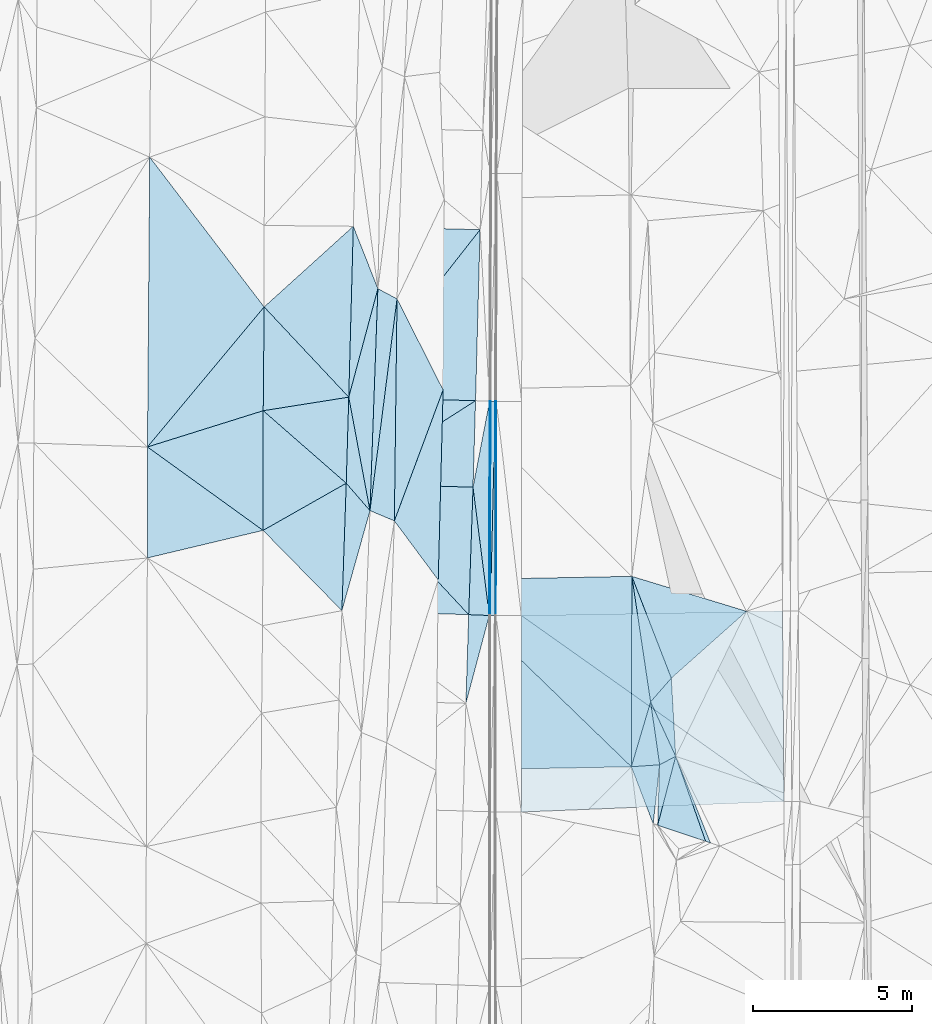
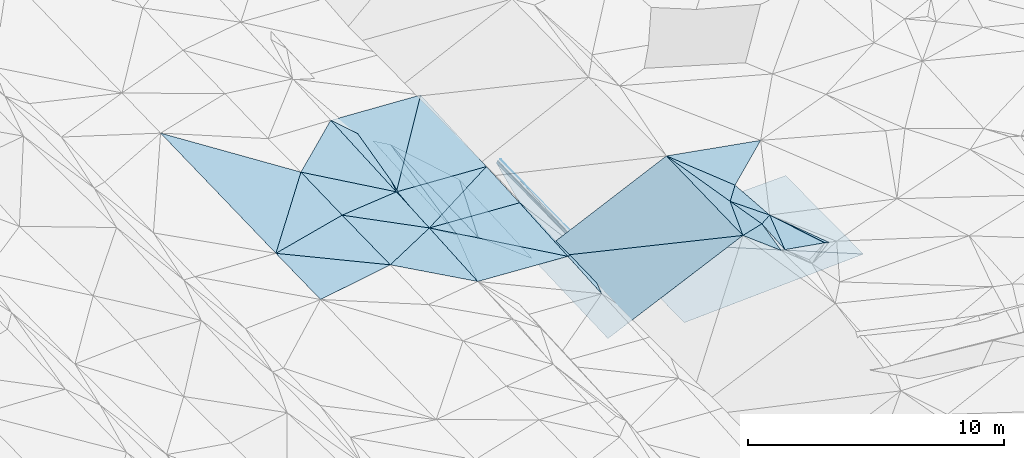
# One storey, part 113 of 275: 45 plates.
"""IFC2X3 building model written with IfcOpenShell, lengths in millimetres."""

from ifc_helpers import new_model, si_unit, frame, origin_with_axes, place, context, subcontext, project, spatial, polyline, outline, extrude, material, type_object, element, save


model = new_model("IFC2X3")

# Units and contexts
model_context = context("Model", 3, precision=1e-05, world=origin_with_axes())
body_context = subcontext(model_context, "Body", "Model", "MODEL_VIEW")
ifc_project = project(units=[si_unit("LENGTHUNIT", "METRE", prefix="MILLI"), si_unit("AREAUNIT", "SQUARE_METRE"), si_unit("VOLUMEUNIT", "CUBIC_METRE"), si_unit("MASSUNIT", "GRAM", prefix="KILO"), si_unit("TIMEUNIT", "SECOND"), si_unit("PLANEANGLEUNIT", "RADIAN"), si_unit("SOLIDANGLEUNIT", "STERADIAN"), si_unit("THERMODYNAMICTEMPERATUREUNIT", "DEGREE_CELSIUS"), si_unit("LUMINOUSINTENSITYUNIT", "LUMEN")], contexts=[model_context])

# Site, building, storey
site_placement = place(None, origin_with_axes())
site = spatial("IfcSite", under=ifc_project, at=site_placement, CompositionType="ELEMENT")
building_placement = place(site_placement, origin_with_axes())
building = spatial("IfcBuilding", under=site, at=building_placement, Name="Undefined", CompositionType="ELEMENT")
storey_placement = place(building_placement, origin_with_axes())
storey = spatial("IfcBuildingStorey", under=building, at=storey_placement, Name="Undefined", CompositionType="ELEMENT", Elevation=0.0)

# Plates
ifc_material = material()
plate_type_1 = type_object("IfcPlateType", PredefinedType="NOTDEFINED")
plate_1_placement = place(storey_placement, frame((-57909.1824641043, 101493.353414711, 43028.0133275653), z_axis=(-0.031047269517772, 0.0185292293777229, -0.999346153599522), x_axis=(-0.61710853961747, -0.786864696567594, 0.00458253497328638)))
element("IfcPlate", 1, at=plate_1_placement, inside=storey, type_object=plate_type_1, material=ifc_material, Name="00_PR", context=body_context, shape_type="SweptSolid", body=[
    extrude(outline(polyline([(0.0, 0.0), (6712.22412109375, -2.40543158724904e-08), (2384.2900390625, 3214.20239257813), (0.0, 0.0)])), frame((-8.85201319254618e-08, 2.18876761149539e-07, -0.5000001331573), z_axis=(0.0, 0.0, 1.0), x_axis=(1.0, 0.0, 0.0)), (0.0, 0.0, 1.0), 1.0),
])
plate_type_2 = type_object("IfcPlateType", PredefinedType="NOTDEFINED")
plate_2_placement = place(storey_placement, frame((-62051.3529860005, 96211.7411999323, 43058.7723184835), z_axis=(-0.0306633647519783, 0.0182280459440001, -0.999363545664515), x_axis=(0.617108539617754, 0.786864696567359, -0.00458253497537088)))
element("IfcPlate", 2, at=plate_2_placement, inside=storey, type_object=plate_type_2, material=ifc_material, Name="00_PR", context=body_context, shape_type="SweptSolid", body=[
    extrude(outline(polyline([(0.0, 0.0), (6712.22412109375, -2.40543158724904e-08), (2380.068359375, 3217.27490234375), (0.0, 0.0)])), frame((-8.85201319254618e-08, 2.18876761149539e-07, -0.5000001331573), z_axis=(0.0, 0.0, 1.0), x_axis=(1.0, 0.0, 0.0)), (0.0, 0.0, 1.0), 1.0),
])
plate_type_3 = type_object("IfcPlateType", PredefinedType="NOTDEFINED")
plate_3_placement = place(storey_placement, frame((-58052.9123680418, 96099.9369413555, 42934.0493217703), z_axis=(-0.0306527454789538, 0.0186005279170604, -0.999357008058586), x_axis=(-0.842895420064381, -0.537844130072321, 0.01584306098071)))
element("IfcPlate", 3, at=plate_3_placement, inside=storey, type_object=plate_type_3, material=ifc_material, Name="00_PR", context=body_context, shape_type="SweptSolid", body=[
    extrude(outline(polyline([(0.0, 0.0), (4837.9541015625, 1.08848325908184e-08), (3312.10986328125, 2246.2216796875), (0.0, 0.0)])), frame((-8.85201319254618e-08, 2.18876761149539e-07, -0.5000001331573), z_axis=(0.0, 0.0, 1.0), x_axis=(1.0, 0.0, 0.0)), (0.0, 0.0, 1.0), 1.0),
])
plate_type_4 = type_object("IfcPlateType", PredefinedType="NOTDEFINED")
plate_4_placement = place(storey_placement, frame((-62130.801419067, 93497.8718170741, 43010.6973171979), z_axis=(-0.0303957004694243, 0.0185568399053159, -0.999365671356437), x_axis=(0.999019561464119, -0.0316325339894895, -0.0309725459954905)))
element("IfcPlate", 4, at=plate_4_placement, inside=storey, type_object=plate_type_4, material=ifc_material, Name="00_PR", context=body_context, shape_type="SweptSolid", body=[
    extrude(outline(polyline([(0.0, 0.0), (4001.93115234375, 7.15954229235649e-09), (3994.52514648438, 4020.86645507813), (0.0, 0.0)])), frame((-8.85201319254618e-08, 2.18876761149539e-07, -0.5000001331573), z_axis=(0.0, 0.0, 1.0), x_axis=(1.0, 0.0, 0.0)), (0.0, 0.0, 1.0), 1.0),
])
plate_5_placement = place(storey_placement, frame((-58269.6130012271, 89353.3534761525, 42816.3013160136), z_axis=(-0.0302048589805003, 0.0187347511255781, -0.999368138172431), x_axis=(-0.999029709474089, 0.0314947659948282, 0.0307850499926167)))
element("IfcPlate", 5, at=plate_5_placement, inside=storey, type_object=plate_type_4, material=ifc_material, Name="00_PR", context=body_context, shape_type="SweptSolid", body=[
    extrude(outline(polyline([(0.0, 0.0), (4001.91015625, 1.07684172689915e-09), (3993.95703125, 4021.43090820313), (0.0, 0.0)])), frame((-8.85201319254618e-08, 2.18876761149539e-07, -0.5000001331573), z_axis=(0.0, 0.0, 1.0), x_axis=(1.0, 0.0, 0.0)), (0.0, 0.0, 1.0), 1.0),
])
plate_type_5 = type_object("IfcPlateType", PredefinedType="NOTDEFINED")
plate_6_placement = place(storey_placement, frame((-57579.2497598258, 96081.7945022669, 43068.247733589), z_axis=(0.970139764418212, 0.00259640183563842, -0.24253267036027), x_axis=(-0.0014779509858692, -0.999860841220768, -0.0166166739807462)))
element("IfcPlate", 6, at=plate_6_placement, inside=storey, type_object=plate_type_5, material=ifc_material, Name="00_PR", context=body_context, shape_type="SweptSolid", body=[
    extrude(outline(polyline([(0.0, 0.0), (6754.7666015625, -3.88390617445111e-08), (6756.96630859375, 123.673530578613), (0.0, 0.0)])), frame((-8.85201319254618e-08, 2.18876761149539e-07, -0.5000001331573), z_axis=(0.0, 0.0, 1.0), x_axis=(1.0, 0.0, 0.0)), (0.0, 0.0, 1.0), 1.0),
])
plate_7_placement = place(storey_placement, frame((-57609.2393043283, 96086.9550963816, 42948.3347430458), z_axis=(0.970144011297878, 0.00259579263473839, -0.242515688571814), x_axis=(0.242410465096964, -0.0417139529857139, 0.969276592381029)))
element("IfcPlate", 7, at=plate_7_placement, inside=storey, type_object=plate_type_5, material=ifc_material, Name="00_PR", context=body_context, shape_type="SweptSolid", body=[
    extrude(outline(polyline([(0.0, 0.0), (123.713912963867, -8.73114913702011e-11), (170.653244018555, 6757.93505859375), (0.0, 0.0)])), frame((-8.85201319254618e-08, 2.18876761149539e-07, -0.5000001331573), z_axis=(0.0, 0.0, 1.0), x_axis=(1.0, 0.0, 0.0)), (0.0, 0.0, 1.0), 1.0),
])
plate_8_placement = place(storey_placement, frame((-51741.9958001236, 84887.2213119148, 45209.5000361991), z_axis=(0.00429473827097584, 0.0127171600984448, -0.999909910473046), x_axis=(0.372999397494959, -0.927775542532137, -0.0101976540241572)))
element("IfcPlate", 8, at=plate_8_placement, inside=storey, type_object=plate_type_5, material=ifc_material, Name="00", context=body_context, shape_type="SweptSolid", body=[
    extrude(outline(polyline([(0.0, 0.0), (2941.85327148438, -1.34077708935365e-08), (2836.00146484375, 123.674690246582), (0.0, 0.0)])), frame((-8.85201319254618e-08, 2.18876761149539e-07, -0.5000001331573), z_axis=(0.0, 0.0, 1.0), x_axis=(1.0, 0.0, 0.0)), (0.0, 0.0, 1.0), 1.0),
])
plate_type_6 = type_object("IfcPlateType", PredefinedType="NOTDEFINED")
plate_9_placement = place(storey_placement, frame((-57429.7352773586, 96081.3448636634, 43067.8690700577), z_axis=(5.05853853107608e-05, 0.0166162104623777, -0.999861939965208), x_axis=(-0.023679539994223, -0.999581560432695, -0.016612748977818)))
element("IfcPlate", 9, at=plate_9_placement, inside=storey, type_object=plate_type_6, material=ifc_material, Name="00_PR", context=body_context, shape_type="SweptSolid", body=[
    extrude(outline(polyline([(0.0, 0.0), (6756.19677734375, 4.00905264541507e-08), (3.09546446800232, 149.968276977539), (0.0, 0.0)])), frame((-8.85201319254618e-08, 2.18876761149539e-07, -0.5000001331573), z_axis=(0.0, 0.0, 1.0), x_axis=(1.0, 0.0, 0.0)), (0.0, 0.0, 1.0), 1.0),
])
plate_10_placement = place(storey_placement, frame((-57589.7189224863, 89327.9750775003, 42955.6300715467), z_axis=(3.61554602707048e-05, 0.0166165522165428, -0.999861934911625), x_axis=(0.023679539977484, 0.999581560433073, 0.0166127489789523)))
element("IfcPlate", 10, at=plate_10_placement, inside=storey, type_object=plate_type_6, material=ifc_material, Name="00_PR", context=body_context, shape_type="SweptSolid", body=[
    extrude(outline(polyline([(0.0, 0.0), (6756.19677734375, 4.00905264541507e-08), (3.22568726539612, 149.965545654297), (0.0, 0.0)])), frame((-8.85201319254618e-08, 2.18876761149539e-07, -0.5000001331573), z_axis=(0.0, 0.0, 1.0), x_axis=(1.0, 0.0, 0.0)), (0.0, 0.0, 1.0), 1.0),
])
plate_type_7 = type_object("IfcPlateType", PredefinedType="NOTDEFINED")
plate_11_placement = place(storey_placement, frame((-57399.7254284312, 96081.2828046263, 43068.4691689635), z_axis=(0.0200276289984239, 0.0165837634610696, -0.999661879270271), x_axis=(-0.0014779509858692, -0.999860841220768, -0.0166166739807462)))
element("IfcPlate", 11, at=plate_11_placement, inside=storey, type_object=plate_type_7, material=ifc_material, Name="00_PR", context=body_context, shape_type="SweptSolid", body=[
    extrude(outline(polyline([(0.0, 0.0), (6754.6005859375, 2.95331119559705e-08), (-0.00772970728576183, 30.0059242248535), (0.0, 0.0)])), frame((-8.85201319254618e-08, 2.18876761149539e-07, -0.5000001331573), z_axis=(0.0, 0.0, 1.0), x_axis=(1.0, 0.0, 0.0)), (0.0, 0.0, 1.0), 1.0),
])
plate_type_8 = type_object("IfcPlateType", PredefinedType="NOTDEFINED")
plate_12_placement = place(storey_placement, frame((-62130.801420121, 93497.8716464225, 43010.6973147425), z_axis=(-0.0304067238909099, 0.0182145384315512, -0.999371633443709), x_axis=(0.84289542009359, 0.537844130026543, -0.0158430609808152)))
element("IfcPlate", 12, at=plate_12_placement, inside=storey, type_object=plate_type_8, material=ifc_material, Name="00_PR", context=body_context, shape_type="SweptSolid", body=[
    extrude(outline(polyline([(0.0, 0.0), (4837.9541015625, 1.08848325908184e-08), (3303.77978515625, 2258.42724609375), (0.0, 0.0)])), frame((-8.85201319254618e-08, 2.18876761149539e-07, -0.5000001331573), z_axis=(0.0, 0.0, 1.0), x_axis=(1.0, 0.0, 0.0)), (0.0, 0.0, 1.0), 1.0),
])
plate_type_9 = type_object("IfcPlateType", PredefinedType="NOTDEFINED")
plate_13_placement = place(storey_placement, frame((-57619.7030336239, 89327.8131730265, 42835.6302992985), z_axis=(0.0303726205335994, 0.0164881932721579, -0.999402643284748), x_axis=(-0.998787722990925, 0.0392506790309626, -0.0297063730235066)))
element("IfcPlate", 13, at=plate_13_placement, inside=storey, type_object=plate_type_9, material=ifc_material, Name="00_PR", context=body_context, shape_type="SweptSolid", body=[
    extrude(outline(polyline([(0.0, 0.0), (650.66845703125, 2.91038304567337e-10), (669.628723144531, 4020.82836914063), (0.0, 0.0)])), frame((-8.85201319254618e-08, 2.18876761149539e-07, -0.5000001331573), z_axis=(0.0, 0.0, 1.0), x_axis=(1.0, 0.0, 0.0)), (0.0, 0.0, 1.0), 1.0),
])
plate_type_10 = type_object("IfcPlateType", PredefinedType="NOTDEFINED")
plate_14_placement = place(storey_placement, frame((-57619.7029439114, 89327.8154792267, 42835.630345053), z_axis=(0.0305510807169254, 0.0210991098977784, -0.999310491803498), x_axis=(-0.257363410154829, -0.96590131045274, -0.0282618750113428)))
element("IfcPlate", 14, at=plate_14_placement, inside=storey, type_object=plate_type_10, material=ifc_material, Name="00_PR", context=body_context, shape_type="SweptSolid", body=[
    extrude(outline(polyline([(0.0, 0.0), (2867.60888671875, -3.56521923094988e-09), (143.133193969727, 634.730102539063), (0.0, 0.0)])), frame((-8.85201319254618e-08, 2.18876761149539e-07, -0.5000001331573), z_axis=(0.0, 0.0, 1.0), x_axis=(1.0, 0.0, 0.0)), (0.0, 0.0, 1.0), 1.0),
])
plate_type_11 = type_object("IfcPlateType", PredefinedType="NOTDEFINED")
plate_15_placement = place(storey_placement, frame((-48372.9398359393, 89465.5210446769, 43139.4062090036), z_axis=(0.0199361821429634, 0.0208941796241239, -0.999582903965148), x_axis=(0.00717807002162699, -0.999758829911683, -0.0207546940325866)))
element("IfcPlate", 15, at=plate_15_placement, inside=storey, type_object=plate_type_11, material=ifc_material, Name="00_PR", context=body_context, shape_type="SweptSolid", body=[
    extrude(outline(polyline([(0.0, 0.0), (6001.29296875, 1.02445483207703e-08), (82.941032409668, 8239.21484375), (0.0, 0.0)])), frame((-8.85201319254618e-08, 2.18876761149539e-07, -0.5000001331573), z_axis=(0.0, 0.0, 1.0), x_axis=(1.0, 0.0, 0.0)), (0.0, 0.0, 1.0), 1.0),
])
plate_type_12 = type_object("IfcPlateType", PredefinedType="NOTDEFINED")
plate_16_placement = place(storey_placement, frame((-56612.1606744668, 83130.2665117395, 42842.2402106643), z_axis=(0.0199833594365093, 0.0209608415354421, -0.999580566271552), x_axis=(0.000395519014383865, 0.999779965678752, 0.0209729299837501)))
element("IfcPlate", 16, at=plate_16_placement, inside=storey, type_object=plate_type_12, material=ifc_material, Name="00_PR", context=body_context, shape_type="SweptSolid", body=[
    extrude(outline(polyline([(0.0, 0.0), (6197.9892578125, -4.14365786127746e-08), (342.231048583984, 8283.818359375), (0.0, 0.0)])), frame((-8.85201319254618e-08, 2.18876761149539e-07, -0.5000001331573), z_axis=(0.0, 0.0, 1.0), x_axis=(1.0, 0.0, 0.0)), (0.0, 0.0, 1.0), 1.0),
])
plate_type_13 = type_object("IfcPlateType", PredefinedType="NOTDEFINED")
plate_17_placement = place(storey_placement, frame((-58132.763165997, 93371.2795966578, 42886.7473081326), z_axis=(0.0309589181989681, 0.0165623431806378, -0.999383427005029), x_axis=(0.189082696950488, 0.981711838874833, 0.0221268869686381)))
element("IfcPlate", 17, at=plate_17_placement, inside=storey, type_object=plate_type_13, material=ifc_material, Name="00_PR", context=body_context, shape_type="SweptSolid", body=[
    extrude(outline(polyline([(0.0, 0.0), (2766.2724609375, 7.10133463144302e-09), (-3873.63891601563, 1269.00939941406), (0.0, 0.0)])), frame((-8.85201319254618e-08, 2.18876761149539e-07, -0.5000001331573), z_axis=(0.0, 0.0, 1.0), x_axis=(1.0, 0.0, 0.0)), (0.0, 0.0, 1.0), 1.0),
])
plate_type_14 = type_object("IfcPlateType", PredefinedType="NOTDEFINED")
plate_18_placement = place(storey_placement, frame((-64748.9594143674, 95784.4997766209, 43149.5004175919), z_axis=(-0.0364187949254546, 0.0194743198151349, -0.999146847187097), x_axis=(0.987153459758247, 0.156343773642656, -0.0329343487941814)))
element("IfcPlate", 18, at=plate_18_placement, inside=storey, type_object=plate_type_14, material=ifc_material, Name="00", context=body_context, shape_type="SweptSolid", body=[
    extrude(outline(polyline([(0.0, 0.0), (2732.70922851563, 3.63797880709171e-10), (2231.63134765625, 2668.861328125), (0.0, 0.0)])), frame((-8.85201319254618e-08, 2.18876761149539e-07, -0.5000001331573), z_axis=(0.0, 0.0, 1.0), x_axis=(1.0, 0.0, 0.0)), (0.0, 0.0, 1.0), 1.0),
])
plate_type_15 = type_object("IfcPlateType", PredefinedType="NOTDEFINED")
plate_19_placement = place(storey_placement, frame((-62051.3559306326, 96211.7414494083, 43059.5004066894), z_axis=(-0.0362898429803615, 0.0186558399600645, -0.999167156651901), x_axis=(-0.987153459759593, -0.156343773635924, 0.0329343487858021)))
element("IfcPlate", 19, at=plate_19_placement, inside=storey, type_object=plate_type_15, material=ifc_material, Name="00", context=body_context, shape_type="SweptSolid", body=[
    extrude(outline(polyline([(0.0, 0.0), (2732.70922851563, 3.63797880709171e-10), (2193.830078125, 3227.39965820313), (0.0, 0.0)])), frame((-8.85201319254618e-08, 2.18876761149539e-07, -0.5000001331573), z_axis=(0.0, 0.0, 1.0), x_axis=(1.0, 0.0, 0.0)), (0.0, 0.0, 1.0), 1.0),
])
plate_type_16 = type_object("IfcPlateType", PredefinedType="NOTDEFINED")
plate_20_placement = place(storey_placement, frame((-52247.0405514895, 84620.1632902487, 45129.5122546152), z_axis=(0.219466432102605, 0.0169454376686293, -0.97547287882461), x_axis=(-0.973100145101167, -0.0680138766063395, -0.220114107210479)))
element("IfcPlate", 20, at=plate_20_placement, inside=storey, type_object=plate_type_16, material=ifc_material, Name="00", context=body_context, shape_type="SweptSolid", body=[
    extrude(outline(polyline([(0.0, 0.0), (917.705810546875, -2.25554686039686e-09), (150.483947753906, 1998.68823242188), (0.0, 0.0)])), frame((-8.85201319254618e-08, 2.18876761149539e-07, -0.5000001331573), z_axis=(0.0, 0.0, 1.0), x_axis=(1.0, 0.0, 0.0)), (0.0, 0.0, 1.0), 1.0),
])
plate_type_17 = type_object("IfcPlateType", PredefinedType="NOTDEFINED")
plate_21_placement = place(storey_placement, frame((-64753.3214400076, 92010.4589089631, 43069.5003542536), z_axis=(-0.0333793791788005, 0.0185434683071331, -0.99927071248425), x_axis=(0.869662253474303, 0.493246066462077, -0.0198968038057701)))
element("IfcPlate", 21, at=plate_21_placement, inside=storey, type_object=plate_type_17, material=ifc_material, Name="00", context=body_context, shape_type="SweptSolid", body=[
    extrude(outline(polyline([(0.0, 0.0), (3015.5595703125, -1.76660250872374e-08), (915.849914550781, 3429.72583007813), (0.0, 0.0)])), frame((-8.85201319254618e-08, 2.18876761149539e-07, -0.5000001331573), z_axis=(0.0, 0.0, 1.0), x_axis=(1.0, 0.0, 0.0)), (0.0, 0.0, 1.0), 1.0),
])
plate_type_18 = type_object("IfcPlateType", PredefinedType="NOTDEFINED")
plate_22_placement = place(storey_placement, frame((-62051.3629793481, 96211.7420575692, 43059.5007253653), z_axis=(-0.0503877000816397, 0.0198719320363894, -0.99853201550958), x_axis=(0.183743897620419, -0.982551395651889, -0.0288259429990274)))
element("IfcPlate", 22, at=plate_22_placement, inside=storey, type_object=plate_type_18, material=ifc_material, Name="00", context=body_context, shape_type="SweptSolid", body=[
    extrude(outline(polyline([(0.0, 0.0), (3642.55224609375, 6.67932908982039e-09), (2653.359375, 577.567138671875), (0.0, 0.0)])), frame((-8.85201319254618e-08, 2.18876761149539e-07, -0.5000001331573), z_axis=(0.0, 0.0, 1.0), x_axis=(1.0, 0.0, 0.0)), (0.0, 0.0, 1.0), 1.0),
])
plate_type_19 = type_object("IfcPlateType", PredefinedType="NOTDEFINED")
plate_23_placement = place(storey_placement, frame((-52451.7345001592, 82758.4144948306, 45059.5122552544), z_axis=(0.219775621378324, 0.012513056749453, -0.975470194141552), x_axis=(-0.356458626525764, 0.931807080706082, -0.0683579689675993)))
element("IfcPlate", 23, at=plate_23_placement, inside=storey, type_object=plate_type_19, material=ifc_material, Name="00", context=body_context, shape_type="SweptSolid", body=[
    extrude(outline(polyline([(0.0, 0.0), (1931.01110839844, -9.22227627597749e-09), (1657.03857421875, 875.855590820313), (0.0, 0.0)])), frame((-8.85201319254618e-08, 2.18876761149539e-07, -0.5000001331573), z_axis=(0.0, 0.0, 1.0), x_axis=(1.0, 0.0, 0.0)), (0.0, 0.0, 1.0), 1.0),
])
plate_type_20 = type_object("IfcPlateType", PredefinedType="NOTDEFINED")
plate_24_placement = place(storey_placement, frame((-61132.9635886085, 99632.1703643896, 43090.5005993574), z_axis=(-0.0444559402826572, 0.0209888055704615, -0.998790838671596), x_axis=(-0.0355593884551744, -0.999178971893906, -0.0194142220480454)))
element("IfcPlate", 24, at=plate_24_placement, inside=storey, type_object=plate_type_20, material=ifc_material, Name="00", context=body_context, shape_type="SweptSolid", body=[
    extrude(outline(polyline([(0.0, 0.0), (7005.173828125, 1.65891833603382e-08), (3450.87890625, 796.977722167969), (0.0, 0.0)])), frame((-8.85201319254618e-08, 2.18876761149539e-07, -0.5000001331573), z_axis=(0.0, 0.0, 1.0), x_axis=(1.0, 0.0, 0.0)), (0.0, 0.0, 1.0), 1.0),
])
plate_25_placement = place(storey_placement, frame((-60613.0616873985, 92310.1866502654, 42751.515445851), z_axis=(-0.245501232519038, 0.02451913855147, -0.969086145126597), x_axis=(-0.896018266847959, 0.375791958382919, 0.23649877270191)))
element("IfcPlate", 25, at=plate_25_placement, inside=storey, type_object=plate_type_20, material=ifc_material, Name="00", context=body_context, shape_type="SweptSolid", body=[
    extrude(outline(polyline([(0.0, 0.0), (858.355407714844, -4.02360456064343e-09), (2593.57592773438, 6507.2119140625), (0.0, 0.0)])), frame((-8.85201319254618e-08, 2.18876761149539e-07, -0.5000001331573), z_axis=(0.0, 0.0, 1.0), x_axis=(1.0, 0.0, 0.0)), (0.0, 0.0, 1.0), 1.0),
])
plate_type_21 = type_object("IfcPlateType", PredefinedType="NOTDEFINED")
plate_26_placement = place(storey_placement, frame((-61382.1791504986, 92632.7516877767, 42954.5196549271), z_axis=(-0.276188217649299, 0.0284953545824028, -0.960681051753872), x_axis=(0.0355593874697877, 0.99917897192909, 0.019414222042132)))
element("IfcPlate", 26, at=plate_26_placement, inside=storey, type_object=plate_type_21, material=ifc_material, Name="00", context=body_context, shape_type="SweptSolid", body=[
    extrude(outline(polyline([(0.0, 0.0), (7005.173828125, 1.65891833603382e-08), (6704.15478515625, 639.610534667969), (0.0, 0.0)])), frame((-8.85201319254618e-08, 2.18876761149539e-07, -0.5000001331573), z_axis=(0.0, 0.0, 1.0), x_axis=(1.0, 0.0, 0.0)), (0.0, 0.0, 1.0), 1.0),
])
plate_type_22 = type_object("IfcPlateType", PredefinedType="NOTDEFINED")
plate_27_placement = place(storey_placement, frame((-62130.8119692653, 93497.872141996, 43009.5007396551), z_axis=(-0.0512335132179543, 0.0191380753753966, -0.998503310557492), x_axis=(0.65366157250058, -0.755262245541784, -0.0480155089033996)))
element("IfcPlate", 27, at=plate_27_placement, inside=storey, type_object=plate_type_22, material=ifc_material, Name="00", context=body_context, shape_type="SweptSolid", body=[
    extrude(outline(polyline([(0.0, 0.0), (1145.46325683594, -1.04228092823178e-09), (2948.92041015625, 2734.16674804688), (0.0, 0.0)])), frame((-8.85201319254618e-08, 2.18876761149539e-07, -0.5000001331573), z_axis=(0.0, 0.0, 1.0), x_axis=(1.0, 0.0, 0.0)), (0.0, 0.0, 1.0), 1.0),
])
plate_type_23 = type_object("IfcPlateType", PredefinedType="NOTDEFINED")
plate_28_placement = place(storey_placement, frame((-52533.5691861114, 86603.6957312772, 45099.5058705989), z_axis=(0.152744079494576, 0.00711519409773328, -0.988240163215555), x_axis=(0.418101060600803, -0.906540910812461, 0.0580954399914289)))
element("IfcPlate", 28, at=plate_28_placement, inside=storey, type_object=plate_type_23, material=ifc_material, Name="00", context=body_context, shape_type="SweptSolid", body=[
    extrude(outline(polyline([(0.0, 0.0), (1893.43603515625, -1.18416210170835e-09), (1919.6845703125, 576.377502441406), (0.0, 0.0)])), frame((-8.85201319254618e-08, 2.18876761149539e-07, -0.5000001331573), z_axis=(0.0, 0.0, 1.0), x_axis=(1.0, 0.0, 0.0)), (0.0, 0.0, 1.0), 1.0),
])
plate_type_24 = type_object("IfcPlateType", PredefinedType="NOTDEFINED")
plate_29_placement = place(storey_placement, frame((-61907.7681725177, 101599.912487801, 43159.5004726285), z_axis=(-0.0392254570162628, 0.0195866469395321, -0.999038401055501), x_axis=(0.366180569753772, -0.92997224608947, -0.0326099959845042)))
element("IfcPlate", 29, at=plate_29_placement, inside=storey, type_object=plate_type_24, material=ifc_material, Name="00", context=body_context, shape_type="SweptSolid", body=[
    extrude(outline(polyline([(0.0, 0.0), (2115.91552734375, 1.17142917588353e-09), (4961.5302734375, 2108.60498046875), (0.0, 0.0)])), frame((-8.85201319254618e-08, 2.18876761149539e-07, -0.5000001331573), z_axis=(0.0, 0.0, 1.0), x_axis=(1.0, 0.0, 0.0)), (0.0, 0.0, 1.0), 1.0),
])
plate_type_25 = type_object("IfcPlateType", PredefinedType="NOTDEFINED")
plate_30_placement = place(storey_placement, frame((-59075.8344859214, 96440.4458394221, 42463.514413653), z_axis=(-0.237566655619112, 0.0207012585433647, -0.971150627880491), x_axis=(-0.0257504894865146, -0.999555743990509, -0.0150075629861817)))
element("IfcPlate", 30, at=plate_30_placement, inside=storey, type_object=plate_type_25, material=ifc_material, Name="00", context=body_context, shape_type="SweptSolid", body=[
    extrude(outline(polyline([(0.0, 0.0), (5996.9765625, -6.02449290454388e-09), (4163.6884765625, 1472.66967773438), (0.0, 0.0)])), frame((-8.85201319254618e-08, 2.18876761149539e-07, -0.5000001331573), z_axis=(0.0, 0.0, 1.0), x_axis=(1.0, 0.0, 0.0)), (0.0, 0.0, 1.0), 1.0),
])
plate_type_26 = type_object("IfcPlateType", PredefinedType="NOTDEFINED")
plate_31_placement = place(storey_placement, frame((-52310.7304847043, 82711.43584705, 45079.5054247086), z_axis=(0.145514098610412, 0.0210580909863684, -0.989132045739905), x_axis=(0.0333183933530873, 0.999102054661556, 0.0261719131021456)))
element("IfcPlate", 31, at=plate_31_placement, inside=storey, type_object=plate_type_26, material=ifc_material, Name="00", context=body_context, shape_type="SweptSolid", body=[
    extrude(outline(polyline([(0.0, 0.0), (1910.44494628906, 4.86761564388871e-09), (2196.18994140625, 501.248260498047), (0.0, 0.0)])), frame((-8.85201319254618e-08, 2.18876761149539e-07, -0.5000001331573), z_axis=(0.0, 0.0, 1.0), x_axis=(1.0, 0.0, 0.0)), (0.0, 0.0, 1.0), 1.0),
])
plate_type_27 = type_object("IfcPlateType", PredefinedType="NOTDEFINED")
plate_32_placement = place(storey_placement, frame((-53140.0708934031, 84557.7499047586, 44927.5100463014), z_axis=(0.198142825464634, 0.0236380144351542, -0.979888087992938), x_axis=(0.00260512738880437, 0.999692931823358, 0.0246425520940196)))
element("IfcPlate", 32, at=plate_32_placement, inside=storey, type_object=plate_type_27, material=ifc_material, Name="00", context=body_context, shape_type="SweptSolid", body=[
    extrude(outline(polyline([(0.0, 0.0), (6005.87158203125, 1.81607902050018e-08), (2051.14453125, 613.343688964844), (0.0, 0.0)])), frame((-8.85201319254618e-08, 2.18876761149539e-07, -0.5000001331573), z_axis=(0.0, 0.0, 1.0), x_axis=(1.0, 0.0, 0.0)), (0.0, 0.0, 1.0), 1.0),
])
plate_type_28 = type_object("IfcPlateType", PredefinedType="NOTDEFINED")
plate_33_placement = place(storey_placement, frame((-51741.9295123471, 84887.2147720217, 45209.5046962305), z_axis=(0.136869514307744, -0.000356758237968602, -0.990589021126684), x_axis=(-0.418101060601715, 0.906540910811971, -0.0580954399925027)))
element("IfcPlate", 33, at=plate_33_placement, inside=storey, type_object=plate_type_28, material=ifc_material, Name="00", context=body_context, shape_type="SweptSolid", body=[
    extrude(outline(polyline([(0.0, 0.0), (1893.43603515625, -1.18416210170835e-09), (2293.185546875, 913.619384765625), (0.0, 0.0)])), frame((-8.85201319254618e-08, 2.18876761149539e-07, -0.5000001331573), z_axis=(0.0, 0.0, 1.0), x_axis=(1.0, 0.0, 0.0)), (0.0, 0.0, 1.0), 1.0),
])
plate_type_29 = type_object("IfcPlateType", PredefinedType="NOTDEFINED")
plate_34_placement = place(storey_placement, frame((-52533.5842404302, 86603.6983192761, 45099.5038027855), z_axis=(0.122635095442042, 0.0122901726863151, -0.992375727746937), x_axis=(-0.14764551961738, 0.989022161847101, -0.00599699192934252)))
element("IfcPlate", 34, at=plate_34_placement, inside=storey, type_object=plate_type_29, material=ifc_material, Name="00", context=body_context, shape_type="SweptSolid", body=[
    extrude(outline(polyline([(0.0, 0.0), (4002.00659179688, 2.28246790356934e-08), (642.83251953125, 762.408264160156), (0.0, 0.0)])), frame((-8.85201319254618e-08, 2.18876761149539e-07, -0.5000001331573), z_axis=(0.0, 0.0, 1.0), x_axis=(1.0, 0.0, 0.0)), (0.0, 0.0, 1.0), 1.0),
])
plate_type_30 = type_object("IfcPlateType", PredefinedType="NOTDEFINED")
plate_35_placement = place(storey_placement, frame((-51741.9585497007, 84887.2344111167, 45209.5019256516), z_axis=(0.0787961288622038, 0.0389179847931599, -0.996130794893909), x_axis=(0.332222438588977, -0.943141857746184, -0.0105682290413552)))
element("IfcPlate", 35, at=plate_35_placement, inside=storey, type_object=plate_type_30, material=ifc_material, Name="00", context=body_context, shape_type="SweptSolid", body=[
    extrude(outline(polyline([(0.0, 0.0), (2838.69677734375, -9.09858499653637e-09), (1864.48229980469, 1264.20166015625), (0.0, 0.0)])), frame((-8.85201319254618e-08, 2.18876761149539e-07, -0.5000001331573), z_axis=(0.0, 0.0, 1.0), x_axis=(1.0, 0.0, 0.0)), (0.0, 0.0, 1.0), 1.0),
])
plate_type_31 = type_object("IfcPlateType", PredefinedType="NOTDEFINED")
plate_36_placement = place(storey_placement, frame((-51880.3069852751, 87351.7250464187, 45189.5003906), z_axis=(0.0328795066408834, -0.0227412796432673, -0.999200566574719), x_axis=(-0.361202453653892, 0.931899937950482, -0.0330952129815662)))
element("IfcPlate", 36, at=plate_36_placement, inside=storey, type_object=plate_type_31, material=ifc_material, Name="00", context=body_context, shape_type="SweptSolid", body=[
    extrude(outline(polyline([(0.0, 0.0), (3444.60693359375, -6.81757228448987e-09), (1107.70544433594, 2972.40454101563), (0.0, 0.0)])), frame((-8.85201319254618e-08, 2.18876761149539e-07, -0.5000001331573), z_axis=(0.0, 0.0, 1.0), x_axis=(1.0, 0.0, 0.0)), (0.0, 0.0, 1.0), 1.0),
])
plate_type_32 = type_object("IfcPlateType", PredefinedType="NOTDEFINED")
plate_37_placement = place(storey_placement, frame((-64753.3279992221, 92010.4610791815, 43069.5006614477), z_axis=(-0.0464978561877177, 0.0228848074373147, -0.998656214599651), x_axis=(-0.971964814621986, -0.231708367583698, 0.0399453567833045)))
element("IfcPlate", 37, at=plate_37_placement, inside=storey, type_object=plate_type_32, material=ifc_material, Name="00", context=body_context, shape_type="SweptSolid", body=[
    extrude(outline(polyline([(0.0, 0.0), (3755.1298828125, -6.85395207256079e-09), (2942.42822265625, 3406.21728515625), (0.0, 0.0)])), frame((-8.85201319254618e-08, 2.18876761149539e-07, -0.5000001331573), z_axis=(0.0, 0.0, 1.0), x_axis=(1.0, 0.0, 0.0)), (0.0, 0.0, 1.0), 1.0),
])
plate_type_33 = type_object("IfcPlateType", PredefinedType="NOTDEFINED")
plate_38_placement = place(storey_placement, frame((-64719.1889162415, 99055.8926017866, 43209.5006283488), z_axis=(-0.0469224266940464, 0.0187444628353025, -0.99872264968116), x_axis=(-0.00909994834125485, -0.999790451353203, -0.0183369660289218)))
element("IfcPlate", 38, at=plate_38_placement, inside=storey, type_object=plate_type_33, material=ifc_material, Name="00", context=body_context, shape_type="SweptSolid", body=[
    extrude(outline(polyline([(0.0, 0.0), (3272.07885742188, -8.44011083245277e-09), (4445.5224609375, 3642.86010742188), (0.0, 0.0)])), frame((-8.85201319254618e-08, 2.18876761149539e-07, -0.5000001331573), z_axis=(0.0, 0.0, 1.0), x_axis=(1.0, 0.0, 0.0)), (0.0, 0.0, 1.0), 1.0),
])
plate_type_34 = type_object("IfcPlateType", PredefinedType="NOTDEFINED")
plate_39_placement = place(storey_placement, frame((-64719.1831570637, 99055.8929732756, 43209.5003982481), z_axis=(-0.035404113181329, 0.0194874968314912, -0.99918305942259), x_axis=(0.741424527443984, 0.670906700384295, -0.0131859578310793)))
element("IfcPlate", 39, at=plate_39_placement, inside=storey, type_object=plate_type_34, material=ifc_material, Name="00", context=body_context, shape_type="SweptSolid", body=[
    extrude(outline(polyline([(0.0, 0.0), (3791.91235351563, 5.4424162954092e-09), (71.8107299804688, 3901.7744140625), (0.0, 0.0)])), frame((-8.85201319254618e-08, 2.18876761149539e-07, -0.5000001331573), z_axis=(0.0, 0.0, 1.0), x_axis=(1.0, 0.0, 0.0)), (0.0, 0.0, 1.0), 1.0),
])
plate_type_35 = type_object("IfcPlateType", PredefinedType="NOTDEFINED")
plate_40_placement = place(storey_placement, frame((-68398.3397364973, 94641.2749245859, 43299.5006350991), z_axis=(-0.0471597839274448, 0.0189425818169327, -0.998707731708344), x_axis=(0.00773895832647979, 0.999797094519637, 0.0185978040131902)))
element("IfcPlate", 40, at=plate_40_placement, inside=storey, type_object=plate_type_35, material=ifc_material, Name="00", context=body_context, shape_type="SweptSolid", body=[
    extrude(outline(polyline([(0.0, 0.0), (9140.8642578125, 5.84113877266645e-08), (4440.52099609375, 3648.955078125), (0.0, 0.0)])), frame((-8.85201319254618e-08, 2.18876761149539e-07, -0.5000001331573), z_axis=(0.0, 0.0, 1.0), x_axis=(1.0, 0.0, 0.0)), (0.0, 0.0, 1.0), 1.0),
])
plate_type_36 = type_object("IfcPlateType", PredefinedType="NOTDEFINED")
plate_41_placement = place(storey_placement, frame((-62130.8037999371, 93497.8731831803, 43009.5004085074), z_axis=(-0.0348950812459833, 0.021220101592649, -0.999165672245216), x_axis=(-0.869662253468603, -0.493246066472106, 0.0198968038062863)))
element("IfcPlate", 41, at=plate_41_placement, inside=storey, type_object=plate_type_36, material=ifc_material, Name="00", context=body_context, shape_type="SweptSolid", body=[
    extrude(outline(polyline([(0.0, 0.0), (3015.5595703125, -1.76660250872374e-08), (1151.82604980469, 3282.72705078125), (0.0, 0.0)])), frame((-8.85201319254618e-08, 2.18876761149539e-07, -0.5000001331573), z_axis=(0.0, 0.0, 1.0), x_axis=(1.0, 0.0, 0.0)), (0.0, 0.0, 1.0), 1.0),
])
plate_type_37 = type_object("IfcPlateType", PredefinedType="NOTDEFINED")
plate_42_placement = place(storey_placement, frame((-64753.3286006184, 92010.4602471319, 43069.5006737372), z_axis=(-0.0476955372163097, 0.021223682677468, -0.998636415830734), x_axis=(-0.809798610601357, 0.584478553704342, 0.0510982438816937)))
element("IfcPlate", 42, at=plate_42_placement, inside=storey, type_object=plate_type_37, material=ifc_material, Name="00", context=body_context, shape_type="SweptSolid", body=[
    extrude(outline(polyline([(0.0, 0.0), (4501.13330078125, 1.58106558956206e-08), (2206.39990234375, 3062.93969726563), (0.0, 0.0)])), frame((-8.85201319254618e-08, 2.18876761149539e-07, -0.5000001331573), z_axis=(0.0, 0.0, 1.0), x_axis=(1.0, 0.0, 0.0)), (0.0, 0.0, 1.0), 1.0),
])
plate_type_38 = type_object("IfcPlateType", PredefinedType="NOTDEFINED")
plate_43_placement = place(storey_placement, frame((-59075.8393910968, 96440.4477437641, 42463.5156920876), z_axis=(-0.247379935215959, 0.0245309157814059, -0.968607971174858), x_axis=(-0.348067391432255, -0.935198724935596, 0.0652107038788999)))
element("IfcPlate", 43, at=plate_43_placement, inside=storey, type_object=plate_type_38, material=ifc_material, Name="00", context=body_context, shape_type="SweptSolid", body=[
    extrude(outline(polyline([(0.0, 0.0), (4416.45263671875, 2.40543158724904e-08), (-2151.47778320313, 2435.71923828125), (0.0, 0.0)])), frame((-8.85201319254618e-08, 2.18876761149539e-07, -0.5000001331573), z_axis=(0.0, 0.0, 1.0), x_axis=(1.0, 0.0, 0.0)), (0.0, 0.0, 1.0), 1.0),
])
plate_type_39 = type_object("IfcPlateType", PredefinedType="NOTDEFINED")
plate_44_placement = place(storey_placement, frame((-53124.3218240379, 90561.776170619, 45075.5427957427), z_axis=(0.404252462324422, 0.021486495804979, -0.914395033452536), x_axis=(-0.00260512744046727, -0.999692931825325, -0.0246425520087642)))
element("IfcPlate", 44, at=plate_44_placement, inside=storey, type_object=plate_type_39, material=ifc_material, Name="00", context=body_context, shape_type="SweptSolid", body=[
    extrude(outline(polyline([(0.0, 0.0), (6005.87158203125, 1.81607902050018e-08), (198.096649169922, 6674.84033203125), (0.0, 0.0)])), frame((-8.85201319254618e-08, 2.18876761149539e-07, -0.5000001331573), z_axis=(0.0, 0.0, 1.0), x_axis=(1.0, 0.0, 0.0)), (0.0, 0.0, 1.0), 1.0),
])
plate_type_40 = type_object("IfcPlateType", PredefinedType="NOTDEFINED")
plate_45_placement = place(storey_placement, frame((-59296.0434065112, 84444.9454581956, 42227.5421098296), z_axis=(0.401318926025843, 0.0178586480044609, -0.91576426459265), x_axis=(0.0110111093999941, 0.999643586667841, 0.0243198499920536)))
element("IfcPlate", 45, at=plate_45_placement, inside=storey, type_object=plate_type_40, material=ifc_material, Name="00", context=body_context, shape_type="SweptSolid", body=[
    extrude(outline(polyline([(0.0, 0.0), (6003.32666015625, 1.08557287603617e-08), (246.210159301758, 6718.58251953125), (0.0, 0.0)])), frame((-8.85201319254618e-08, 2.18876761149539e-07, -0.5000001331573), z_axis=(0.0, 0.0, 1.0), x_axis=(1.0, 0.0, 0.0)), (0.0, 0.0, 1.0), 1.0),
])

save(model, "model.ifc")
